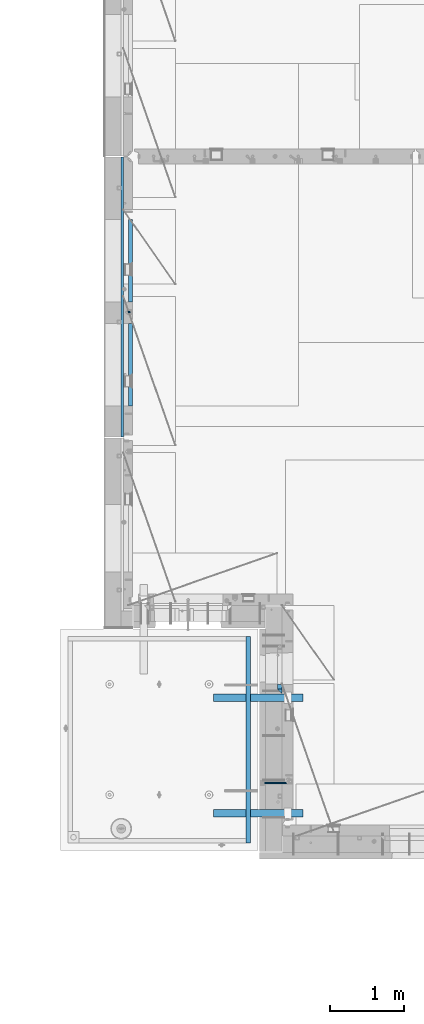
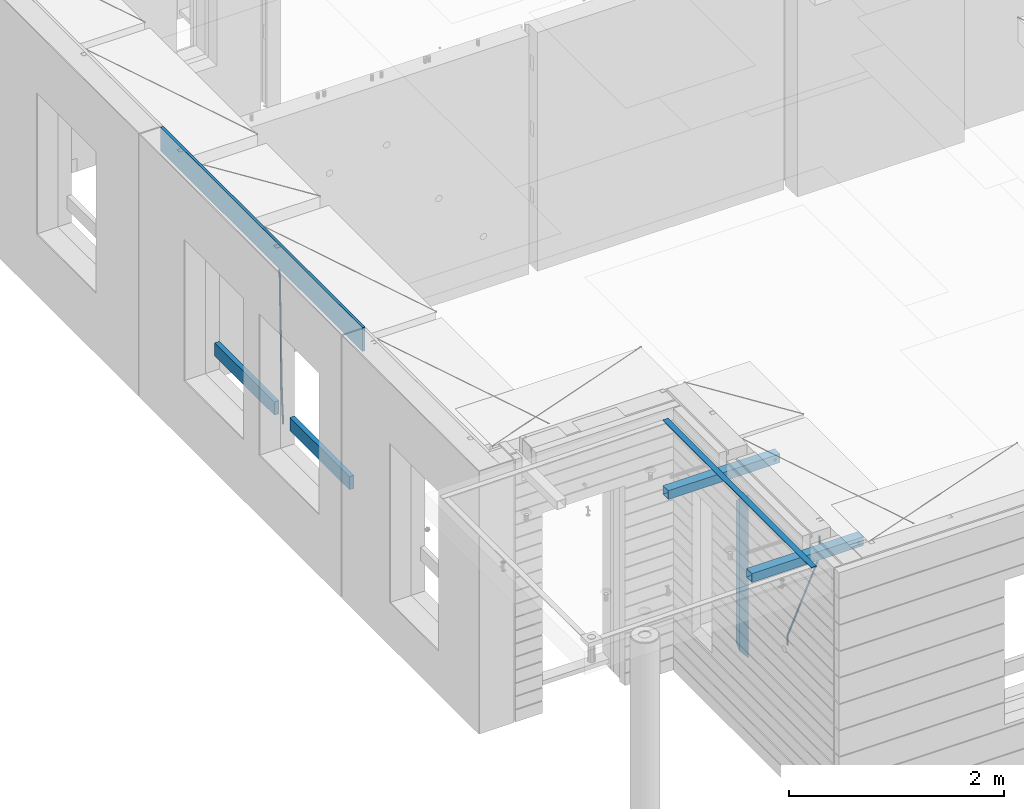
# One storey, part 93 of 349: 10 beams, 5 elements without a shape of their own.
"""IFC2X3 building model written with IfcOpenShell, lengths in millimetres."""

from ifc_helpers import new_model, si_unit, frame, origin_with_axes, place, context, subcontext, project, spatial, faceted_brep, material, type_object, element, aggregate, save


model = new_model("IFC2X3")

# Units and contexts
model_context = context("Model", 3, precision=1e-05, world=origin_with_axes())
body_context = subcontext(model_context, "Body", "Model", "MODEL_VIEW")
ifc_project = project(units=[si_unit("LENGTHUNIT", "METRE", prefix="MILLI"), si_unit("AREAUNIT", "SQUARE_METRE"), si_unit("VOLUMEUNIT", "CUBIC_METRE"), si_unit("MASSUNIT", "GRAM", prefix="KILO"), si_unit("TIMEUNIT", "SECOND"), si_unit("PLANEANGLEUNIT", "RADIAN"), si_unit("SOLIDANGLEUNIT", "STERADIAN"), si_unit("THERMODYNAMICTEMPERATUREUNIT", "DEGREE_CELSIUS"), si_unit("LUMINOUSINTENSITYUNIT", "LUMEN")], contexts=[model_context])

# Site, building, storey
site_placement = place(None, origin_with_axes())
site = spatial("IfcSite", under=ifc_project, at=site_placement, CompositionType="ELEMENT")
building_placement = place(site_placement, origin_with_axes())
building = spatial("IfcBuilding", under=site, at=building_placement, CompositionType="ELEMENT")
storey_placement = place(building_placement, origin_with_axes())
storey = spatial("IfcBuildingStorey", under=building, at=storey_placement, Name="4", CompositionType="ELEMENT", Elevation=0.0)

# Assembly, beam
assembly_1_placement = place(storey_placement, origin_with_axes())
assembly_1 = element("IfcElementAssembly", 1, at=assembly_1_placement, inside=storey, AssemblyPlace="NOTDEFINED", PredefinedType="REINFORCEMENT_UNIT")
ifc_material_1 = material()
beam_type_1 = type_object("IfcBeamType", Name="D20", PredefinedType="NOTDEFINED")
beam_1_placement = place(assembly_1_placement, frame((7964.99984877319, 14888.5021362169, 91590.0), z_axis=(-0.999642804636942, -0.000205726999925762, -0.0267249099902983), x_axis=(-0.0267249099948371, 4.30000201934385e-08, 0.999642825806181)))
beam_1 = element("IfcBeam", 2, at=beam_1_placement, type_object=beam_type_1, material=ifc_material_1, Name="JM20", ObjectType="D20", context=body_context, shape_type="Brep", body=[
    faceted_brep([(0.0, -10.0, 0.0), (-4.19531716033816e-08, -7.07106781186667, -7.07106781187031), (60.4266690400545, -7.0710677960451, -7.07106780570757), (60.4266690441291, -9.99999998418934, 6.15546014159918e-09), (0.0, 0.0, -10.0), (60.426669036824, 1.58106558956206e-08, -9.99999999384454), (4.196772351861e-08, 7.07106781186303, -7.07106781186667), (60.4266690363438, 7.07106782768096, -7.07106780570757), (0.0, 10.0, 0.0), (60.4266690388904, 10.0000000158179, 6.15182216279209e-09), (4.196772351861e-08, 7.07106781185939, 7.07106781185939), (60.4266690429649, 7.07106782768096, 7.07106781802577), (0.0, 0.0, 10.0), (60.4266690461809, 1.58179318532348e-08, 10.0000000061555), (-4.19531716033816e-08, -7.07106781187031, 7.07106781185939), (60.4266690466611, -7.07106779605238, 7.07106781802213), (61.0378400410118, -7.07106779588503, -7.07106780564936), (60.991799419251, -9.99999998403655, 6.21366780251265e-09), (61.0569027789461, 1.5985278878361e-08, -9.99999999378269), (61.0378209396877, 7.07106782784831, -7.07106780564936), (60.9917724058905, 10.0000000159635, 6.21366780251265e-09), (60.9457317841297, 7.07106782781193, 7.0710678180767), (60.9266690461809, 1.59488990902901e-08, 10.0000000062028), (60.9457508854539, -7.07106779591413, 7.0710678180767), (61.6489592143771, -7.07106614513759, -7.06310863441468), (61.5568818710308, -9.9999984576425, 0.00735959856683621), (61.6870830769039, 1.71821739058942e-06, -9.99179257185824), (61.6489210170112, 7.07106947854481, -7.06310888312146), (61.556827851804, 10.0000015422847, 0.00735924683976918), (61.4647505084577, 7.07106922979438, 7.07782747982128), (61.4266266459163, 1.36643211590126e-06, 10.0065114172685), (61.464788705809, -7.07106639389531, 7.07782772852806), (176.543135720174, -7.07075579406956, -5.56673531796696), (176.451058376813, -9.99968810657447, 1.50373291501455), (176.581259582701, 0.000312069292704109, -8.49541925541052), (176.543097522794, 7.07137982961285, -5.56673556667374), (176.451004357587, 10.00031189336, 1.50373256329476), (176.35892701424, 7.07137958085514, 8.57420079627263), (176.320803151699, 0.000311717507429421, 11.5028847337162), (176.358965211621, -7.07075604281999, 8.57420104497578), (177.098753836006, -7.07075429323595, -5.55949898843028), (176.98362511232, -9.99968666800123, 1.510669025065), (177.146421932586, 0.000313595905026887, -8.48805862247536), (177.098706077581, 7.07138133041735, -5.55949936166144), (176.983557571715, 10.0003133318824, 1.51066849724157), (176.868428848029, 7.07138095712435, 8.58083651073321), (176.820760751449, 0.000313067976094317, 11.5093961447819), (176.868476606425, -7.07075466652896, 8.58083688396073), (177.654312950661, -7.07075204110879, -5.54863964998367), (177.516135294456, -9.99968450931192, 1.52107783331303), (177.711524267797, 0.000315886711177882, -8.47701274570863), (177.654255632195, 7.07138358250813, -5.54864021007961), (177.516054233929, 10.0003154905207, 1.5210770412159), (177.377876577739, 7.0713830223176, 8.59079452451624), (177.320665260588, 0.000315094497636892, 11.5191676202448), (177.377933896176, -7.07075260129932, 8.59079508461218), (299.461778333818, -7.07025827596954, -3.16770791544877), (299.323600677439, -9.99919074416357, 3.90200956798253), (299.518989651391, 0.000809651852250681, -6.09608101123195), (299.46172101624, 7.07187734764193, -3.16770847554471), (299.323519618119, 10.0008092556727, 3.90200877589086), (299.18534196174, 7.07187678747687, 10.971726259324), (299.128130644167, 0.000808859655080596, 13.9000993551072), (299.185399279333, -7.07025883613824, 10.9717268194163), (300.005099199436, -7.07025607348805, -3.15708779472698), (299.971788958996, -9.99918809853989, 3.91467979818117), (300.018894160545, 0.00081167833377549, -6.08630953626562), (300.005085253739, 7.07187955030167, -3.15708750704471), (299.971753863239, 10.0008119014747, 3.91467990454839), (299.93844362146, 7.0718798403559, 10.9864468987271), (299.924648660366, 0.000812088532256894, 13.9156686402657), (299.938457567187, -7.07025578343564, 10.9864466110448), (300.548496018673, -7.07025720445017, -3.16258750978159), (300.620052478174, -9.9991894658433, 3.90811820064846), (300.518868553889, 0.000810637746326393, -6.09136977328126), (300.548525450897, 7.07187841925042, -3.16258766112878), (300.620094101629, 10.000810534113, 3.90811798661343), (300.69165056113, 7.07187827271991, 10.9788236970453), (300.721278025885, 0.000810430521596572, 13.907605960545), (300.691621128892, -7.07025735098068, 10.9788238483907), (1693.63216510082, -7.07315660432141, -17.2619766794614), (1693.70372156033, -10.0020888657109, -10.1912709690314), (1693.60253763606, -0.00208876212127507, -20.1907589429611), (1693.63219453306, 7.068979019381, -17.2619768308086), (1693.7037631838, 9.9979111342418, -10.1912711830664), (1693.77531964328, 7.06897887284867, -3.12056547263455), (1693.80494710806, -0.00208896934782388, -0.191783209134883), (1693.77529021105, -7.0731567508501, -3.12056532128736), (1694.29779868275, -7.07315798969103, -17.2687135518572), (1694.26743251897, -10.0020900389554, -10.1969762833342), (1694.34857500881, -0.00209031483609579, -20.1983095815103), (1694.39001741401, 7.06897744213711, -17.2696467503938), (1694.39784949942, 9.99790968965317, -10.1982960253627), (1694.36748333565, 7.06897764038877, -3.12655875683777), (1694.3167070096, -0.00209003446616407, -0.196962727188293), (1694.2752646044, -7.07315779143937, -3.125625558303), (1694.96335083364, -7.08183692566672, -17.2598557114488), (1694.83107451542, -10.0094400457037, -10.1894747662172), (1695.09452111425, -0.0118176043979474, -20.1883817771341), (1695.14774758583, 7.05909648594388, -17.259562111758), (1695.09185090323, 9.98885976961174, -10.1890595535533), (1694.95957458501, 7.0612566495729, -3.11867860832172), (1694.82840430441, -0.00876267169223865, -0.190152542638316), (1694.77517783281, -7.07967676203589, -3.11897220801256), (1716.74088258609, -7.36582038739652, -16.9700183177756), (1716.60860626785, -10.2934235074299, -9.8996373725422), (1716.87205286669, -0.295801066125932, -19.898544383459), (1716.92527933829, 6.77511302421226, -16.9697247180848), (1716.86938265568, 9.70487630788193, -9.89922215988008), (1716.73710633747, 6.77727318784673, -2.82884121464849), (1716.60593605686, -0.292746133423861, 0.0996848510367272), (1716.55270958526, -7.36366022376751, -2.82913481433934), (1717.37632925155, -7.37410674169405, -16.9615611515819), (1717.2686961548, -10.302031214369, -9.89085222946233), (1717.45037731848, -0.30334253509136, -19.8908474573927), (1717.44746400231, 6.76830362954752, -16.96277495703), (1717.36929588411, 9.6983573372836, -9.89256880959147), (1717.26166278738, 6.77043286460685, -2.82185988747187), (1717.18761472043, -0.300331341994024, 0.107426418340765), (1717.1905280366, -7.3719775066329, -2.82064608202199), (1718.0118297398, -7.37223067542982, -16.9532990407679), (1717.92884180055, -10.3000626540106, -9.8822625771154), (1718.02875100763, -0.301644694996867, -19.8833453418993), (1717.96969335481, 6.76984191386691, -16.9560200956876), (1717.86925195342, 9.69984820183527, -9.88611072988533), (1717.78626401415, 6.77201622325447, -2.81507426623284), (1717.76934274634, -0.298569757178484, 0.114972034898528), (1717.82840039914, -7.37005636604226, -2.81235321131317), (1818.03261514839, -7.07396855575644, -15.6559248891263), (1817.94962720915, -10.0018005343409, -8.58488842547376), (1818.04953641623, -0.00338257532712305, -18.5859711902594), (1817.99047876342, 7.06810403353848, -15.6586459440477), (1817.89003736203, 9.99811032150683, -8.58873657824552), (1817.80704942276, 7.07027834292421, -1.51770011459121), (1817.79012815493, -0.00030763750692131, 1.41234618654016), (1817.84918580775, -7.07179424637252, -1.51497905967153)], [[[0, 1, 2, 3]], [[1, 4, 5, 2]], [[4, 6, 7, 5]], [[6, 8, 9, 7]], [[8, 10, 11, 9]], [[10, 12, 13, 11]], [[12, 14, 15, 13]], [[14, 0, 3, 15]], [[14, 12, 10, 8, 6, 4, 1, 0]], [[3, 2, 16, 17]], [[2, 5, 18, 16]], [[5, 7, 19, 18]], [[7, 9, 20, 19]], [[9, 11, 21, 20]], [[11, 13, 22, 21]], [[13, 15, 23, 22]], [[15, 3, 17, 23]], [[17, 16, 24, 25]], [[16, 18, 26, 24]], [[18, 19, 27, 26]], [[19, 20, 28, 27]], [[20, 21, 29, 28]], [[21, 22, 30, 29]], [[22, 23, 31, 30]], [[23, 17, 25, 31]], [[25, 24, 32, 33]], [[24, 26, 34, 32]], [[26, 27, 35, 34]], [[27, 28, 36, 35]], [[28, 29, 37, 36]], [[29, 30, 38, 37]], [[30, 31, 39, 38]], [[31, 25, 33, 39]], [[33, 32, 40, 41]], [[32, 34, 42, 40]], [[34, 35, 43, 42]], [[35, 36, 44, 43]], [[36, 37, 45, 44]], [[37, 38, 46, 45]], [[38, 39, 47, 46]], [[39, 33, 41, 47]], [[41, 40, 48, 49]], [[40, 42, 50, 48]], [[42, 43, 51, 50]], [[43, 44, 52, 51]], [[44, 45, 53, 52]], [[45, 46, 54, 53]], [[46, 47, 55, 54]], [[47, 41, 49, 55]], [[49, 48, 56, 57]], [[48, 50, 58, 56]], [[50, 51, 59, 58]], [[51, 52, 60, 59]], [[52, 53, 61, 60]], [[53, 54, 62, 61]], [[54, 55, 63, 62]], [[55, 49, 57, 63]], [[57, 56, 64, 65]], [[56, 58, 66, 64]], [[58, 59, 67, 66]], [[59, 60, 68, 67]], [[60, 61, 69, 68]], [[61, 62, 70, 69]], [[62, 63, 71, 70]], [[63, 57, 65, 71]], [[65, 64, 72, 73]], [[64, 66, 74, 72]], [[66, 67, 75, 74]], [[67, 68, 76, 75]], [[68, 69, 77, 76]], [[69, 70, 78, 77]], [[70, 71, 79, 78]], [[71, 65, 73, 79]], [[73, 72, 80, 81]], [[72, 74, 82, 80]], [[74, 75, 83, 82]], [[75, 76, 84, 83]], [[76, 77, 85, 84]], [[77, 78, 86, 85]], [[78, 79, 87, 86]], [[79, 73, 81, 87]], [[81, 80, 88, 89]], [[80, 82, 90, 88]], [[82, 83, 91, 90]], [[83, 84, 92, 91]], [[84, 85, 93, 92]], [[85, 86, 94, 93]], [[86, 87, 95, 94]], [[87, 81, 89, 95]], [[89, 88, 96, 97]], [[88, 90, 98, 96]], [[90, 91, 99, 98]], [[91, 92, 100, 99]], [[92, 93, 101, 100]], [[93, 94, 102, 101]], [[94, 95, 103, 102]], [[95, 89, 97, 103]], [[97, 96, 104, 105]], [[96, 98, 106, 104]], [[98, 99, 107, 106]], [[99, 100, 108, 107]], [[100, 101, 109, 108]], [[101, 102, 110, 109]], [[102, 103, 111, 110]], [[103, 97, 105, 111]], [[105, 104, 112, 113]], [[104, 106, 114, 112]], [[106, 107, 115, 114]], [[107, 108, 116, 115]], [[108, 109, 117, 116]], [[109, 110, 118, 117]], [[110, 111, 119, 118]], [[111, 105, 113, 119]], [[113, 112, 120, 121]], [[112, 114, 122, 120]], [[114, 115, 123, 122]], [[115, 116, 124, 123]], [[116, 117, 125, 124]], [[117, 118, 126, 125]], [[118, 119, 127, 126]], [[119, 113, 121, 127]], [[121, 120, 128, 129]], [[120, 122, 130, 128]], [[122, 123, 131, 130]], [[123, 124, 132, 131]], [[124, 125, 133, 132]], [[125, 126, 134, 133]], [[126, 127, 135, 134]], [[127, 121, 129, 135]], [[130, 131, 132, 133, 134, 135, 129, 128]]]),
])

assembly_2_placement = place(storey_placement, origin_with_axes())
assembly_2 = element("IfcElementAssembly", 3, at=assembly_2_placement, inside=storey, AssemblyPlace="NOTDEFINED", PredefinedType="REINFORCEMENT_UNIT")
beam_2_placement = place(assembly_2_placement, frame((10084.9999999647, 8564.98166687309, 93407.5), z_axis=(-0.999999913638316, 0.000415599999849952, 0.0), x_axis=(0.0, 0.000121133999959918, -0.999999992663277)))
beam_2 = element("IfcBeam", 4, at=beam_2_placement, type_object=beam_type_1, material=ifc_material_1, Name="JM20", ObjectType="D20", context=body_context, shape_type="Brep", body=[
    faceted_brep([(-0.00060564729210455, -9.99999998165731, 0.0), (-0.000428079845733009, -7.07106779890455, -7.07106781186667), (119.575515501536, -7.07830994756296, -7.07106481604933), (119.575337932896, -10.0072421307195, -3.43332612828817e-06), (0.0, 0.0, -10.0), (119.575943836026, -0.00724214867295814, -9.99999700418266), (0.00042843479604926, 7.07106779888636, -7.07106781186303), (119.57637202373, 7.06382565022977, -7.07106481604933), (0.00060564729210455, 9.99999998166459, 3.63797880709171e-12), (119.576549238118, 9.99275783300072, 2.99581552098971e-06), (0.000428079845733009, 7.07106779890819, 7.07106781186667), (119.576371669405, 7.06382565024978, 7.07107080768037), (0.0, 0.0, 10.0), (119.57594333493, -0.00724214864203532, 10.0000029958155), (-0.000428434810601175, -7.07106779888272, 7.07106781186667), (119.575515147211, -7.07830994754295, 7.07107080768037), (123.007405723343, -7.07815237794966, -6.96784054723321), (122.582805401355, -10.007113663476, 0.0904711304865486), (123.182426022089, -0.00707257534122618, -9.89150983141735), (123.005342715085, 7.06398309518409, -6.96790640923791), (122.579888801934, 9.9928861221324, 0.0903624855927774), (122.155289414804, 7.06392483519267, 7.14865866135005), (121.980269116029, -0.00715496741395327, 10.0723279455269), (122.157352422975, -7.0782106379429, 7.14872452334748), (237.078231779073, -7.06149109115177, -0.0988580894754705), (236.653632119254, -9.99044140063779, 6.95944262285229), (237.253252738476, 0.00958416329558531, -3.02253833409122), (237.076170091008, 7.08064438202746, -0.0989458723961434), (236.650716449905, 10.0095583892689, 6.95931848240434), (236.226116787962, 7.08060808260052, 14.0176191980772), (236.051095828545, 0.00953282815316925, 16.941299442693), (236.228178476013, -7.0615273905787, 14.0177069809979), (256.716784942022, -7.05713112583726, 4.66796457641431), (253.8595186116, -9.98662150758355, 11.1357894837274), (257.898622726789, 0.0141676527291565, 1.98866675801037), (256.712727422928, 7.08500390428708, 4.66739235003661), (253.853780415884, 10.0133776500024, 11.1349802305504), (250.996514088198, 7.08388726532212, 17.6028051349822), (249.814676303416, 0.0125884867593413, 20.2821029533789), (251.000571607292, -7.05824776480404, 17.6033773613526), (1009.8418691523, -6.8275857616245, 337.477127600083), (1006.98460282487, -9.75707614622661, 343.94495250464), (1011.02370693708, 0.243713016892798, 334.797829781568), (1009.83781163342, 7.31454926845799, 337.476555373547), (1006.97886462661, 10.2429230142297, 343.944143254112), (1004.1215982992, 7.31343262962582, 350.411968158671), (1002.9397605144, 0.24213385110852, 353.091265977184), (1004.12565581808, -6.82870240045668, 350.412540385207), (1010.86419861369, -6.82727416533089, 337.928899317039), (1009.37206741578, -9.75634846973117, 344.999983214544), (1011.48104282112, 0.24385240851916, 334.999928444824), (1010.8612610672, 7.31486120611044, 337.928822011047), (1009.36791309767, 10.2436511734759, 344.99987388736), (1007.87578189977, 7.31457686907379, 352.070957784867), (1007.25893769236, 0.243450295225557, 354.999928657082), (1007.87871944626, -6.8275585023639, 352.071035090858), (1011.98189950881, -6.82713877372771, 337.928899260769), (1011.98225465103, -9.75603228725959, 344.999983083137), (1011.98104281745, 0.243912975529383, 334.999928419653), (1011.98018641509, 7.31499674603583, 337.928821954716), (1011.97983197065, 10.2439675657079, 344.999873755865), (1011.98018711284, 7.31507405217599, 352.070957578235), (1011.98104380422, 0.244022302918893, 354.999928419351), (1011.98190020656, -6.82706146758574, 352.071034884289), (1117.50085144035, -6.81435683895143, 337.928893948503), (1117.50120658254, -9.7432503524833, 344.999977770873), (1117.49999474897, 0.256694910305669, 334.999923107387), (1117.49913834663, 7.32777868081212, 337.92881664245), (1117.49878390216, 10.2567495004841, 344.9998684436), (1117.49913904438, 7.32785598695227, 352.070952265971), (1117.49999573575, 0.256804237695178, 354.999923107087), (1117.5008521381, -6.81427953280945, 352.071029572024)], [[[0, 1, 2, 3]], [[1, 4, 5, 2]], [[4, 6, 7, 5]], [[6, 8, 9, 7]], [[8, 10, 11, 9]], [[10, 12, 13, 11]], [[12, 14, 15, 13]], [[14, 0, 3, 15]], [[14, 12, 10, 8, 6, 4, 1, 0]], [[3, 2, 16, 17]], [[2, 5, 18, 16]], [[5, 7, 19, 18]], [[7, 9, 20, 19]], [[9, 11, 21, 20]], [[11, 13, 22, 21]], [[13, 15, 23, 22]], [[15, 3, 17, 23]], [[17, 16, 24, 25]], [[16, 18, 26, 24]], [[18, 19, 27, 26]], [[19, 20, 28, 27]], [[20, 21, 29, 28]], [[21, 22, 30, 29]], [[22, 23, 31, 30]], [[23, 17, 25, 31]], [[25, 24, 32, 33]], [[24, 26, 34, 32]], [[26, 27, 35, 34]], [[27, 28, 36, 35]], [[28, 29, 37, 36]], [[29, 30, 38, 37]], [[30, 31, 39, 38]], [[31, 25, 33, 39]], [[33, 32, 40, 41]], [[32, 34, 42, 40]], [[34, 35, 43, 42]], [[35, 36, 44, 43]], [[36, 37, 45, 44]], [[37, 38, 46, 45]], [[38, 39, 47, 46]], [[39, 33, 41, 47]], [[41, 40, 48, 49]], [[40, 42, 50, 48]], [[42, 43, 51, 50]], [[43, 44, 52, 51]], [[44, 45, 53, 52]], [[45, 46, 54, 53]], [[46, 47, 55, 54]], [[47, 41, 49, 55]], [[49, 48, 56, 57]], [[48, 50, 58, 56]], [[50, 51, 59, 58]], [[51, 52, 60, 59]], [[52, 53, 61, 60]], [[53, 54, 62, 61]], [[54, 55, 63, 62]], [[55, 49, 57, 63]], [[57, 56, 64, 65]], [[56, 58, 66, 64]], [[58, 59, 67, 66]], [[59, 60, 68, 67]], [[60, 61, 69, 68]], [[61, 62, 70, 69]], [[62, 63, 71, 70]], [[63, 57, 65, 71]], [[66, 67, 68, 69, 70, 71, 65, 64]]]),
])

# Beam
ifc_material_2 = material(Name="TIMBER/T24")
beam_type_2 = type_object("IfcBeamType", PredefinedType="NOTDEFINED")
beam_3_placement = place(assembly_1_placement, frame((7975.00000026382, 14735.0004107749, 91685.0), z_axis=(0.0, 0.0, 1.0), x_axis=(0.0, -1.0, 0.0)))
beam_3 = element("IfcBeam", 5, at=beam_3_placement, type_object=beam_type_2, material=ifc_material_2, context=body_context, shape_type="Brep", body=[
    faceted_brep([(-3.63797880709171e-12, 24.9999999999964, -75.0), (-3.63797880709171e-12, 24.9999999999964, 75.0), (1110.0, 24.9999999999964, 75.0), (1110.0, 24.9999999999964, -75.0), (0.0, -25.0000000000073, 75.0), (1110.0, -25.0000000000073, 75.0), (0.0, -25.0000000000073, -75.0), (1110.0, -25.0000000000073, -75.0)], [[[0, 1, 2, 3]], [[1, 4, 5, 2]], [[4, 6, 7, 5]], [[6, 0, 3, 7]], [[5, 7, 3, 2]], [[6, 4, 1, 0]]]),
])

beam_4_placement = place(assembly_1_placement, frame((7975.00000026382, 16134.5170325064, 91685.0), z_axis=(0.0, 0.0, 1.0), x_axis=(0.0, -1.0, 0.0)))
beam_4 = element("IfcBeam", 6, at=beam_4_placement, type_object=beam_type_2, material=ifc_material_2, context=body_context, shape_type="Brep", body=[
    faceted_brep([(-3.63797880709171e-12, 24.9999999999964, -75.0), (-3.63797880709171e-12, 24.9999999999964, 75.0), (1109.51662173163, 25.0, 75.0), (1109.51662173163, 25.0, -75.0), (0.0, -25.0000000000073, 75.0), (1109.51662173163, -25.0, 75.0), (0.0, -25.0000000000073, -75.0), (1109.51662173163, -25.0, -75.0)], [[[0, 1, 2, 3]], [[1, 4, 5, 2]], [[4, 6, 7, 5]], [[6, 0, 3, 7]], [[5, 7, 3, 2]], [[6, 4, 1, 0]]]),
])

# Assemblies, beams
assembly_3_placement = place(storey_placement, origin_with_axes())
assembly_3 = element("IfcElementAssembly", 7, at=assembly_3_placement, inside=storey, AssemblyPlace="NOTDEFINED", PredefinedType="REINFORCEMENT_UNIT")
assembly_4_placement = place(assembly_3_placement, origin_with_axes())
assembly_4 = element("IfcElementAssembly", 8, at=assembly_4_placement, AssemblyPlace="NOTDEFINED", PredefinedType="NOTDEFINED")
ifc_material_3 = material(Name="Undefined/350")
beam_type_3 = type_object("IfcBeamType", Name="100X100X5", PredefinedType="NOTDEFINED")
beam_5_placement = place(assembly_4_placement, frame((9089.99655739692, 9710.00014320107, 93555.0), z_axis=(0.0, 0.0, 1.0), x_axis=(0.999999999752625, -2.22429999942101e-05, 0.0)))
beam_5 = element("IfcBeam", 9, at=beam_5_placement, type_object=beam_type_3, material=ifc_material_3, ObjectType="100X100X5", context=body_context, shape_type="Brep", body=[
    faceted_brep([(1156.2510802317, 44.9999999999982, 10.8253175473074), (1156.25107855315, 50.0256005946221, 10.8253175473074), (1160.82639610046, 50.0256021227788, 6.25), (1160.82639777901, 44.9999999999982, 6.25), (1150.00108023171, 44.9999999999982, 12.5), (1150.00107855316, 50.0255985071226, 12.5), (1143.75108023171, 44.9999999999982, 10.8253175473074), (1143.75107855316, 50.0255964196231, 10.8253175473074), (1139.1757626844, 44.9999999999982, 6.25), (1139.17576100585, 50.0255948914664, 6.25), (1137.5010802317, 44.9999999999982, 0.0), (1137.50107855316, 50.0255943321226, 0.0), (1139.1757626844, 44.9999999999982, -6.25), (1139.17576100585, 50.0255948914664, -6.25), (1143.75108023171, 44.9999999999982, -10.8253175473074), (1143.75107855316, 50.0255964196231, -10.8253175473074), (1150.00108023171, 44.9999999999982, -12.5), (1150.00107855316, 50.0255985071226, -12.5), (1156.2510802317, 44.9999999999982, -10.8253175473074), (1156.25107855315, 50.0256005946221, -10.8253175473074), (1160.82639777901, 44.9999999999982, -6.25), (1160.82639610046, 50.0256021227788, -6.25), (1162.50108023171, 44.9999999999982, 0.0), (1162.50107855316, 50.0256026821226, 0.0), (1156.25111195316, -49.9743994042774, 10.8253175473074), (1156.25111029171, -44.9999999999991, 10.8253175473074), (1160.82642783901, -44.9999999999991, 6.25), (1160.82642950046, -49.9743978761207, 6.25), (1150.00111195316, -49.9744014917787, 12.5), (1150.00111029171, -44.9999999999991, 12.5), (1143.75111195316, -49.9744035792783, 10.8253175473074), (1143.75111029171, -44.9999999999991, 10.8253175473074), (1139.17579440585, -49.9744051074349, 6.25), (1139.1757927444, -44.9999999999991, 6.25), (1137.50111195316, -49.9744056667778, 0.0), (1137.50111029171, -44.9999999999991, 0.0), (1139.17579440585, -49.9744051074349, -6.25), (1139.1757927444, -44.9999999999991, -6.25), (1143.75111195316, -49.9744035792783, -10.8253175473074), (1143.75111029171, -44.9999999999991, -10.8253175473074), (1150.00111195316, -49.9744014917787, -12.5), (1150.00111029171, -44.9999999999991, -12.5), (1156.25111195316, -49.9743994042774, -10.8253175473074), (1156.25111029171, -44.9999999999991, -10.8253175473074), (1160.82642950046, -49.9743978761207, -6.25), (1160.82642783901, -44.9999999999991, -6.25), (1162.50111195316, -49.9743973167779, 0.0), (1162.50111029171, -44.9999999999991, 0.0), (1.81898940354586e-12, -50.0000000000009, -50.0), (1.81898940354586e-12, 49.9999999999991, -50.0), (1200.00449189278, 49.9999999999982, -50.0), (1200.00449189278, -50.0000000000009, -50.0), (1.81898940354586e-12, 49.9999999999991, 50.0), (1.81898940354586e-12, -50.0000000000009, 50.0), (1200.00449189278, -50.0000000000009, 50.0), (1200.00449189278, 49.9999999999982, 50.0), (0.0, 44.9999999999991, 45.0), (1.81898940354586e-12, -45.0000000000009, 45.0), (1.81898940354586e-12, -45.0000000000009, -45.0), (0.0, 44.9999999999991, -45.0), (1200.00449189278, 44.9999999999982, -45.0), (1200.00449189278, 44.9999999999982, 45.0), (1200.00449189278, -45.0000000000009, 45.0), (1200.00449189278, -45.0000000000009, -45.0)], [[[0, 1, 2, 3]], [[4, 5, 1, 0]], [[6, 7, 5, 4]], [[8, 9, 7, 6]], [[10, 11, 9, 8]], [[12, 13, 11, 10]], [[14, 15, 13, 12]], [[16, 17, 15, 14]], [[18, 19, 17, 16]], [[20, 21, 19, 18]], [[22, 23, 21, 20]], [[3, 2, 23, 22]], [[24, 25, 26, 27]], [[28, 29, 25, 24]], [[30, 31, 29, 28]], [[32, 33, 31, 30]], [[34, 35, 33, 32]], [[36, 37, 35, 34]], [[38, 39, 37, 36]], [[40, 41, 39, 38]], [[42, 43, 41, 40]], [[44, 45, 43, 42]], [[46, 47, 45, 44]], [[27, 26, 47, 46]], [[48, 49, 50, 51]], [[52, 53, 54, 55]], [[49, 52, 55, 50], [1, 5, 7, 9, 11, 13, 15, 17, 19, 21, 23, 2]], [[48, 53, 52, 49], [56, 57, 58, 59]], [[56, 59, 60, 61], [18, 16, 14, 12, 10, 8, 6, 4, 0, 3, 22, 20]], [[57, 56, 61, 62]], [[58, 57, 62, 63], [25, 29, 31, 33, 35, 37, 39, 41, 43, 45, 47, 26]], [[59, 58, 63, 60]], [[54, 51, 50, 55], [62, 61, 60, 63]], [[53, 48, 51, 54], [42, 40, 38, 36, 34, 32, 30, 28, 24, 27, 46, 44]]]),
])
aggregate(assembly_4, [beam_5])
assembly_5_placement = place(assembly_3_placement, origin_with_axes())
assembly_5 = element("IfcElementAssembly", 10, at=assembly_5_placement, AssemblyPlace="NOTDEFINED", PredefinedType="NOTDEFINED")
beam_6_placement = place(assembly_5_placement, frame((9089.99655739692, 8155.00014320107, 93555.0), z_axis=(0.0, 0.0, 1.0), x_axis=(0.999999999752625, -2.22429999942101e-05, 0.0)))
beam_6 = element("IfcBeam", 11, at=beam_6_placement, type_object=beam_type_3, material=ifc_material_3, ObjectType="100X100X5", context=body_context, shape_type="Brep", body=[
    faceted_brep([(1156.2510802317, 44.9999999999982, 10.8253175473074), (1156.25107855315, 50.0256005946221, 10.8253175473074), (1160.82639610046, 50.0256021227788, 6.25), (1160.82639777901, 44.9999999999982, 6.25), (1150.00108023171, 44.9999999999982, 12.5), (1150.00107855316, 50.0255985071226, 12.5), (1143.75108023171, 44.9999999999982, 10.8253175473074), (1143.75107855316, 50.0255964196231, 10.8253175473074), (1139.1757626844, 44.9999999999982, 6.25), (1139.17576100585, 50.0255948914664, 6.25), (1137.5010802317, 44.9999999999982, 0.0), (1137.50107855316, 50.0255943321226, 0.0), (1139.1757626844, 44.9999999999982, -6.25), (1139.17576100585, 50.0255948914664, -6.25), (1143.75108023171, 44.9999999999982, -10.8253175473074), (1143.75107855316, 50.0255964196231, -10.8253175473074), (1150.00108023171, 44.9999999999982, -12.5), (1150.00107855316, 50.0255985071226, -12.5), (1156.2510802317, 44.9999999999982, -10.8253175473074), (1156.25107855315, 50.0256005946221, -10.8253175473074), (1160.82639777901, 44.9999999999982, -6.25), (1160.82639610046, 50.0256021227788, -6.25), (1162.50108023171, 44.9999999999982, 0.0), (1162.50107855316, 50.0256026821226, 0.0), (1156.25111195316, -49.9743994042774, 10.8253175473074), (1156.25111029171, -44.9999999999991, 10.8253175473074), (1160.82642783901, -44.9999999999991, 6.25), (1160.82642950046, -49.9743978761207, 6.25), (1150.00111195316, -49.9744014917787, 12.5), (1150.00111029171, -44.9999999999991, 12.5), (1143.75111195316, -49.9744035792783, 10.8253175473074), (1143.75111029171, -44.9999999999991, 10.8253175473074), (1139.17579440585, -49.9744051074349, 6.25), (1139.1757927444, -44.9999999999991, 6.25), (1137.50111195316, -49.9744056667778, 0.0), (1137.50111029171, -44.9999999999991, 0.0), (1139.17579440585, -49.9744051074349, -6.25), (1139.1757927444, -44.9999999999991, -6.25), (1143.75111195316, -49.9744035792783, -10.8253175473074), (1143.75111029171, -44.9999999999991, -10.8253175473074), (1150.00111195316, -49.9744014917787, -12.5), (1150.00111029171, -44.9999999999991, -12.5), (1156.25111195316, -49.9743994042774, -10.8253175473074), (1156.25111029171, -44.9999999999991, -10.8253175473074), (1160.82642950046, -49.9743978761207, -6.25), (1160.82642783901, -44.9999999999991, -6.25), (1162.50111195316, -49.9743973167779, 0.0), (1162.50111029171, -44.9999999999991, 0.0), (1.81898940354586e-12, -50.0000000000009, -50.0), (1.81898940354586e-12, 49.9999999999991, -50.0), (1200.00449189278, 49.9999999999982, -50.0), (1200.00449189278, -50.0000000000009, -50.0), (1.81898940354586e-12, 49.9999999999991, 50.0), (1.81898940354586e-12, -50.0000000000009, 50.0), (1200.00449189278, -50.0000000000009, 50.0), (1200.00449189278, 49.9999999999982, 50.0), (0.0, 44.9999999999991, 45.0), (1.81898940354586e-12, -45.0000000000009, 45.0), (1.81898940354586e-12, -45.0000000000009, -45.0), (0.0, 44.9999999999991, -45.0), (1200.00449189278, 44.9999999999982, -45.0), (1200.00449189278, 44.9999999999982, 45.0), (1200.00449189278, -45.0000000000009, 45.0), (1200.00449189278, -45.0000000000009, -45.0)], [[[0, 1, 2, 3]], [[4, 5, 1, 0]], [[6, 7, 5, 4]], [[8, 9, 7, 6]], [[10, 11, 9, 8]], [[12, 13, 11, 10]], [[14, 15, 13, 12]], [[16, 17, 15, 14]], [[18, 19, 17, 16]], [[20, 21, 19, 18]], [[22, 23, 21, 20]], [[3, 2, 23, 22]], [[24, 25, 26, 27]], [[28, 29, 25, 24]], [[30, 31, 29, 28]], [[32, 33, 31, 30]], [[34, 35, 33, 32]], [[36, 37, 35, 34]], [[38, 39, 37, 36]], [[40, 41, 39, 38]], [[42, 43, 41, 40]], [[44, 45, 43, 42]], [[46, 47, 45, 44]], [[27, 26, 47, 46]], [[48, 49, 50, 51]], [[52, 53, 54, 55]], [[49, 52, 55, 50], [1, 5, 7, 9, 11, 13, 15, 17, 19, 21, 23, 2]], [[48, 53, 52, 49], [56, 57, 58, 59]], [[56, 59, 60, 61], [18, 16, 14, 12, 10, 8, 6, 4, 0, 3, 22, 20]], [[57, 56, 61, 62]], [[58, 57, 62, 63], [25, 29, 31, 33, 35, 37, 39, 41, 43, 45, 47, 26]], [[59, 58, 63, 60]], [[54, 51, 50, 55], [62, 61, 60, 63]], [[53, 48, 51, 54], [42, 40, 38, 36, 34, 32, 30, 28, 24, 27, 46, 44]]]),
])
aggregate(assembly_5, [beam_6])
ifc_material_4 = material(Name="CONCRETE/Concrete_Undefined")
beam_type_4 = type_object("IfcBeamType", PredefinedType="NOTDEFINED")
beam_7_placement = place(assembly_3_placement, frame((9559.6242765169, 7760.00786459139, 93724.2917943147), z_axis=(-2.9999991954625e-09, -0.000129499999950134, 0.999999991614875), x_axis=(2.43220000075427e-05, 0.999999991319095, 0.000129500000041638)))
beam_7 = element("IfcBeam", 12, at=beam_7_placement, type_object=beam_type_4, material=ifc_material_4, context=body_context, shape_type="Brep", body=[
    faceted_brep([(2.5465851649642e-11, 29.9999999999982, -4.99999999998545), (-2.91038304567337e-11, 29.9999999999982, 5.0), (2770.00002322912, 29.9999999999982, 5.00000000001455), (2770.00002322912, 29.9999999999982, -4.9999999999709), (-2.5465851649642e-11, -30.0000000000018, 5.0), (2770.00002322912, -30.0000000000018, 5.0), (2.72848410531878e-11, -30.0000000000018, -4.99999999998545), (2770.00002322912, -30.0000000000018, -4.99999999998545)], [[[0, 1, 2, 3]], [[1, 4, 5, 2]], [[4, 6, 7, 5]], [[6, 0, 3, 7]], [[5, 7, 3, 2]], [[6, 4, 1, 0]]]),
])
aggregate(assembly_3, [assembly_4, assembly_5, beam_7])

# Beam
ifc_material_5 = material(Name="CONCRETE/C25/30")
beam_type_5 = type_object("IfcBeamType", PredefinedType="NOTDEFINED")
beam_8_placement = place(assembly_2_placement, frame((9980.0, 9795.00042424099, 93175.0), z_axis=(0.0, 1.0, 0.0), x_axis=(0.0, 0.0, -1.0)))
beam_8 = element("IfcBeam", 13, at=beam_8_placement, type_object=beam_type_5, material=ifc_material_5, Name="SK", context=body_context, shape_type="Brep", body=[
    faceted_brep([(60.0000000000073, 30.0, 30.0), (0.0, -30.0, -30.0), (60.0000000000073, -30.0, 30.0), (1795.00000000001, -30.0, 30.0), (1795.00000000001, 30.0, 30.0), (1855.0, -30.0, -30.0)], [[[0, 1, 2]], [[3, 4, 0, 2]], [[4, 5, 1, 0]], [[5, 3, 2, 1]], [[3, 5, 4]]]),
])

beam_type_6 = type_object("IfcBeamType", PredefinedType="NOTDEFINED")
beam_9_placement = place(assembly_2_placement, frame((9980.00000000155, 9860.00042424099, 93115.0), z_axis=(0.0, 1.0, 0.0), x_axis=(0.0, 0.0, -1.0)))
beam_9 = element("IfcBeam", 14, at=beam_9_placement, type_object=beam_type_6, material=ifc_material_5, Name="SK", context=body_context, shape_type="Brep", body=[
    faceted_brep([(0.0, -30.0, -35.0), (54.9034748914273, -30.0, 29.0540540540533), (56.2934362811066, 30.0, 30.6756756756768), (0.0, 30.0, -35.0), (1680.09652510857, -30.0, 29.0540540540533), (1678.70656371891, 30.0, 30.6756756756768), (1735.0, 30.0, -35.0), (1735.0, -30.0, -35.0)], [[[0, 1, 2, 3]], [[2, 1, 4, 5]], [[3, 2, 5, 6]], [[6, 7, 0, 3]], [[1, 0, 7, 4]], [[7, 6, 5, 4]]]),
])

aggregate(assembly_2, [beam_2, beam_8, beam_9])

beam_type_7 = type_object("IfcBeamType", Name="270X30", PredefinedType="NOTDEFINED")
beam_10_placement = place(assembly_1_placement, frame((7865.00000036742, 16969.9999989039, 93605.0), z_axis=(0.0, 0.0, 1.0), x_axis=(0.0, -1.0, 0.0)))
beam_10 = element("IfcBeam", 15, at=beam_10_placement, type_object=beam_type_7, material=ifc_material_5, ObjectType="270X30", context=body_context, shape_type="Brep", body=[
    faceted_brep([(0.0, 15.0, -135.0), (0.0, 15.0, 135.0), (3759.99957708467, 15.0, 135.0), (3759.99957708467, 15.0, -135.0), (0.0, -15.0, 135.0), (3759.99957708467, -15.0, 135.0), (0.0, -15.0, -135.0), (3759.99957708467, -15.0, -135.0)], [[[0, 1, 2, 3]], [[1, 4, 5, 2]], [[4, 6, 7, 5]], [[6, 0, 3, 7]], [[5, 7, 3, 2]], [[6, 4, 1, 0]]]),
])

aggregate(assembly_1, [beam_1, beam_3, beam_10, beam_4])

save(model, "model.ifc")
